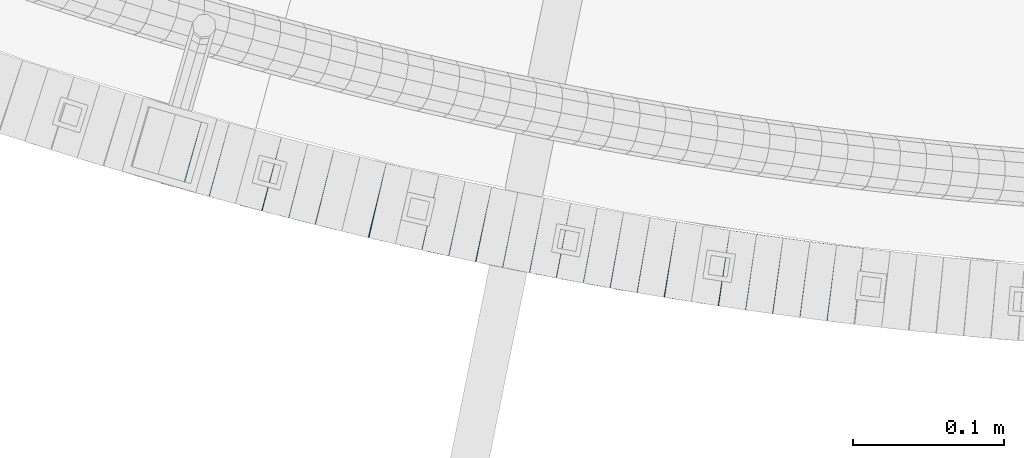
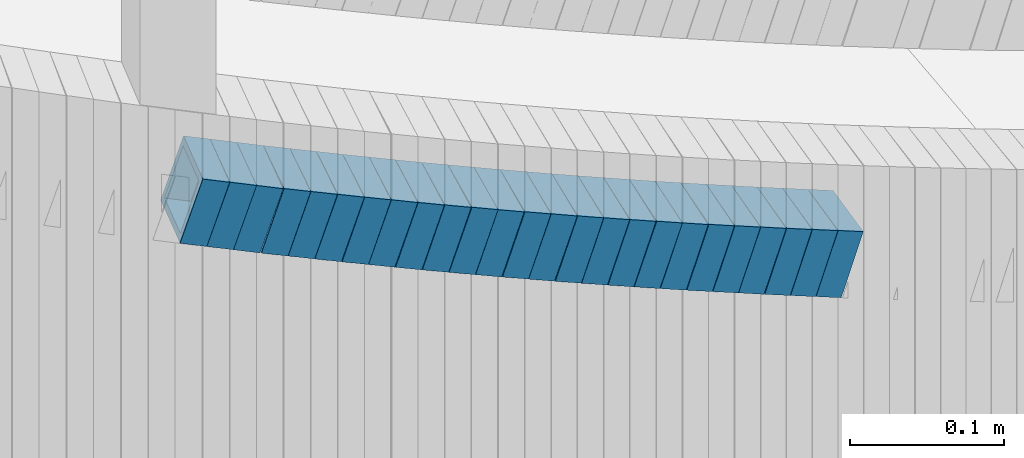
# One storey, part 671 of 975: 25 beams.
"""IFC2X3 building model written with IfcOpenShell, lengths in millimetres."""

from ifc_helpers import new_model, si_unit, frame, origin_with_axes, place, context, subcontext, project, spatial, faceted_brep, material, type_object, element, save


model = new_model("IFC2X3")

# Units and contexts
model_context = context("Model", 3, precision=1e-05, world=origin_with_axes())
body_context = subcontext(model_context, "Body", "Model", "MODEL_VIEW")
ifc_project = project(units=[si_unit("LENGTHUNIT", "METRE", prefix="MILLI"), si_unit("AREAUNIT", "SQUARE_METRE"), si_unit("VOLUMEUNIT", "CUBIC_METRE"), si_unit("MASSUNIT", "GRAM", prefix="KILO"), si_unit("TIMEUNIT", "SECOND"), si_unit("PLANEANGLEUNIT", "RADIAN"), si_unit("SOLIDANGLEUNIT", "STERADIAN"), si_unit("THERMODYNAMICTEMPERATUREUNIT", "DEGREE_CELSIUS"), si_unit("LUMINOUSINTENSITYUNIT", "LUMEN")], contexts=[model_context])

# Site, building, storey
site_placement = place(None, origin_with_axes())
site = spatial("IfcSite", under=ifc_project, at=site_placement, CompositionType="ELEMENT")
building_placement = place(site_placement, origin_with_axes())
building = spatial("IfcBuilding", under=site, at=building_placement, Name="Undefined", CompositionType="ELEMENT")
storey_placement = place(building_placement, origin_with_axes())
storey = spatial("IfcBuildingStorey", under=building, at=storey_placement, Name="Undefined", CompositionType="ELEMENT", Elevation=0.0)

# Beams
ifc_material = material()
beam_type = type_object("IfcBeamType", Name="HSS2X2X.188_TUBES", PredefinedType="NOTDEFINED")
for number, where, z_axis, x_axis, name in (
    (1, (33942.9680907817, 644.253471281401, 3543.29082249187), (0.267356577272934, 0.963597665308972, 2.4865676095942e-10), (0.918421532894371, -0.254822158970696, -0.302601313965203), "WALL"),
    (2, (33960.2608075269, 639.412258861512, 3537.63333455663), (0.262173284244731, 0.965020812743607, -9.81567609414923e-11), (0.918162800504618, -0.249443072865418, -0.307823366833929), "WALL"),
    (3, (33977.5608075269, 634.71225886151, 3531.83333455663), (0.262173284244731, 0.965020812743607, -9.81567609414923e-11), (0.918162800504618, -0.249443072865418, -0.307823366833929), "WALL"),
):
    element("IfcBeam", number, at=place(storey_placement, frame(where, z_axis=z_axis, x_axis=x_axis)), inside=storey, type_object=beam_type, material=ifc_material, Name=name, ObjectType="HSS2X2X.188_TUBES", context=body_context, shape_type="Brep", body=[
        faceted_brep([(0.0, 20.6374999999753, -20.6375000000298), (0.0, -20.6375000000153, -20.6375000000153), (18.8433011969464, -20.6374999999898, -20.6375000000226), (18.8433011969719, 20.6375000000007, -20.6374999999862), (0.0, -20.6374999999825, 20.6375000000335), (18.8433011969828, -20.6375000000044, 20.6375000000189), (0.0, 20.6375000000116, 20.6375000000189), (18.8433011970155, 20.6374999999862, 20.6375000000517), (0.0, 25.3999999999724, -25.4000000000342), (0.0, 25.400000000016, 25.4000000000196), (18.8433011970228, 25.3999999999833, 25.4000000000597), (18.8433011969719, 25.4000000000015, -25.3999999999869), (0.0, -25.399999999976, 25.4000000000378), (18.8433011969864, -25.4000000000051, 25.4000000000196), (0.0, -25.400000000016, -25.4000000000196), (18.8433011969391, -25.3999999999869, -25.4000000000269)], [[[0, 1, 2, 3]], [[1, 4, 5, 2]], [[4, 6, 7, 5]], [[6, 0, 3, 7]], [[8, 9, 10, 11]], [[9, 12, 13, 10]], [[12, 14, 15, 13]], [[14, 8, 11, 15]], [[13, 15, 11, 10], [5, 7, 3, 2]], [[14, 12, 9, 8], [6, 4, 1, 0]]]),
    ])
beam_1_placement = place(storey_placement, frame((33995.2713785459, 629.805617457047, 3525.98848877912), z_axis=(0.250382821654522, 0.968146911692807, 8.16853571450337e-11), x_axis=(0.922846449748657, -0.238667184934995, -0.302311767917665)))
element("IfcBeam", 4, at=beam_1_placement, inside=storey, type_object=beam_type, material=ifc_material, Name="WALL", ObjectType="HSS2X2X.188_TUBES", context=body_context, shape_type="Brep", body=[
    faceted_brep([(0.0, 20.6374999999753, -20.6375000000298), (0.0, -20.6375000000153, -20.6375000000153), (18.8480768248774, -20.6374999999716, -20.6375000000735), (18.8480768249356, 20.6375000000153, -20.6375000000226), (0.0, -20.6374999999825, 20.6375000000335), (18.8480768249283, -20.6374999999935, 20.6374999999716), (0.0, 20.6375000000116, 20.6375000000189), (18.8480768249865, 20.6374999999935, 20.6375000000262), (0.0, 25.3999999999724, -25.4000000000342), (0.0, 25.400000000016, 25.4000000000196), (18.848076825001, 25.3999999999887, 25.4000000000378), (18.8480768249392, 25.4000000000142, -25.4000000000233), (0.0, -25.399999999976, 25.4000000000378), (18.8480768249283, -25.399999999996, 25.3999999999833), (0.0, -25.400000000016, -25.4000000000196), (18.8480768248664, -25.3999999999687, -25.4000000000779)], [[[0, 1, 2, 3]], [[1, 4, 5, 2]], [[4, 6, 7, 5]], [[6, 0, 3, 7]], [[8, 9, 10, 11]], [[9, 12, 13, 10]], [[12, 14, 15, 13]], [[14, 8, 11, 15]], [[13, 15, 11, 10], [5, 7, 3, 2]], [[14, 12, 9, 8], [6, 4, 1, 0]]]),
])
beam_2_placement = place(storey_placement, frame((34012.7165786276, 625.262051182556, 3520.30361280791), z_axis=(0.246487962209947, 0.969145853050813, 2.48490778176347e-10), x_axis=(0.923221587142403, -0.234807802036218, -0.304182835046923)))
element("IfcBeam", 5, at=beam_2_placement, inside=storey, type_object=beam_type, material=ifc_material, Name="WALL", ObjectType="HSS2X2X.188_TUBES", context=body_context, shape_type="Brep", body=[
    faceted_brep([(0.0, 20.6374999999753, -20.6375000000298), (0.0, -20.6375000000153, -20.6375000000153), (18.7416648140024, -20.6375000000153, -20.6374999999825), (18.7416648139188, 20.6375000000189, -20.6375000000298), (0.0, -20.6374999999825, 20.6375000000335), (18.7416648140097, -20.6375000000189, 20.6375000000226), (0.0, 20.6375000000116, 20.6375000000189), (18.741664813926, 20.6375000000153, 20.6374999999753), (0.0, 25.3999999999724, -25.4000000000342), (0.0, 25.400000000016, 25.4000000000196), (18.7416648139224, 25.4000000000196, 25.3999999999687), (18.7416648139042, 25.4000000000233, -25.4000000000378), (0.0, -25.399999999976, 25.4000000000378), (18.7416648140133, -25.4000000000215, 25.4000000000269), (0.0, -25.400000000016, -25.4000000000196), (18.7416648140133, -25.4000000000196, -25.399999999976)], [[[0, 1, 2, 3]], [[1, 4, 5, 2]], [[4, 6, 7, 5]], [[6, 0, 3, 7]], [[8, 9, 10, 11]], [[9, 12, 13, 10]], [[12, 14, 15, 13]], [[14, 8, 11, 15]], [[13, 15, 11, 10], [5, 7, 3, 2]], [[14, 12, 9, 8], [6, 4, 1, 0]]]),
])
beam_3_placement = place(storey_placement, frame((34030.0797760681, 620.791852995655, 3514.63379787298), z_axis=(0.239909191617451, 0.970795333619533, 9.06384229892865e-11), x_axis=(0.923639222967941, -0.228255669992075, -0.307879740989314)))
element("IfcBeam", 6, at=beam_3_placement, inside=storey, type_object=beam_type, material=ifc_material, Name="WALL", ObjectType="HSS2X2X.188_TUBES", context=body_context, shape_type="Brep", body=[
    faceted_brep([(0.0, 20.6374999999753, -20.6375000000298), (0.0, -20.6375000000153, -20.6375000000153), (18.8433011969464, -20.6374999999898, -20.6375000000226), (18.8433011969719, 20.6375000000007, -20.6374999999862), (0.0, -20.6374999999825, 20.6375000000335), (18.8433011969828, -20.6375000000044, 20.6375000000189), (0.0, 20.6375000000116, 20.6375000000189), (18.8433011970155, 20.6374999999862, 20.6375000000517), (0.0, 25.3999999999724, -25.4000000000342), (0.0, 25.400000000016, 25.4000000000196), (18.8433011970228, 25.3999999999833, 25.4000000000597), (18.8433011969719, 25.4000000000015, -25.3999999999869), (0.0, -25.399999999976, 25.4000000000378), (18.8433011969864, -25.4000000000051, 25.4000000000196), (0.0, -25.400000000016, -25.4000000000196), (18.8433011969391, -25.3999999999869, -25.4000000000269)], [[[0, 1, 2, 3]], [[1, 4, 5, 2]], [[4, 6, 7, 5]], [[6, 0, 3, 7]], [[8, 9, 10, 11]], [[9, 12, 13, 10]], [[12, 14, 15, 13]], [[14, 8, 11, 15]], [[13, 15, 11, 10], [5, 7, 3, 2]], [[14, 12, 9, 8], [6, 4, 1, 0]]]),
])
for number, where, z_axis, x_axis, name in (
    (7, (34047.7134620733, 616.391430923569, 3508.79749634809), (0.234640533210091, 0.972082208547654, -9.88338797469624e-11), (0.926252882322659, -0.223578282077887, -0.303427668105709), "WALL"),
    (8, (34065.1099416318, 612.148817747955, 3503.13981683548), (0.229351114565448, 0.973343755436684, 1.69726263266057e-10), (0.925833205726166, -0.218156099935475, -0.308611067908709), "WALL"),
):
    element("IfcBeam", number, at=place(storey_placement, frame(where, z_axis=z_axis, x_axis=x_axis)), inside=storey, type_object=beam_type, material=ifc_material, Name=name, ObjectType="HSS2X2X.188_TUBES", context=body_context, shape_type="Brep", body=[
        faceted_brep([(0.0, 20.6374999999753, -20.6375000000298), (0.0, -20.6375000000153, -20.6375000000153), (18.7853666454903, -20.6375000000535, -20.6375000000326), (18.785366645363, 20.6374999999862, -20.6375000000044), (0.0, -20.6374999999825, 20.6375000000335), (18.785366645352, -20.6375000000007, 20.6374999999989), (0.0, 20.6375000000116, 20.6375000000189), (18.7853666453102, 20.6375000000025, 20.6374999999753), (0.0, 25.3999999999724, -25.4000000000342), (0.0, 25.400000000016, 25.4000000000196), (18.7853666452065, 25.4000000000451, 25.4000000000351), (18.7853666453739, 25.3999999999833, -25.400000000006), (0.0, -25.399999999976, 25.4000000000378), (18.7853666497213, -25.399999993424, 25.3999999995158), (0.0, -25.400000000016, -25.4000000000196), (18.7853666455194, -25.4000000000633, -25.4000000000406)], [[[0, 1, 2, 3]], [[1, 4, 5, 2]], [[4, 6, 7, 5]], [[6, 0, 3, 7]], [[8, 9, 10, 11]], [[9, 12, 13, 10]], [[12, 14, 15, 13]], [[14, 8, 11, 15]], [[13, 15, 11, 10], [5, 7, 3, 2]], [[14, 12, 9, 8], [6, 4, 1, 0]]]),
    ])
beam_4_placement = place(storey_placement, frame((34082.7459201724, 607.950333243549, 3497.30322650391), z_axis=(0.22404129864445, 0.974579651183888, 1.23778590932488e-10), x_axis=(0.928412719816283, -0.213428210957767, -0.304135200939811)))
element("IfcBeam", 9, at=beam_4_placement, inside=storey, type_object=beam_type, material=ifc_material, Name="WALL", ObjectType="HSS2X2X.188_TUBES", context=body_context, shape_type="Brep", body=[
    faceted_brep([(0.0, 20.6374999999753, -20.6375000000298), (0.0, -20.6375000000153, -20.6375000000153), (18.7416648140024, -20.6375000000153, -20.6374999999825), (18.7416648139188, 20.6375000000189, -20.6375000000298), (0.0, -20.6374999999825, 20.6375000000335), (18.7416648140097, -20.6375000000189, 20.6375000000226), (0.0, 20.6375000000116, 20.6375000000189), (18.741664813926, 20.6375000000153, 20.6374999999753), (0.0, 25.3999999999724, -25.4000000000342), (0.0, 25.400000000016, 25.4000000000196), (18.7416648139224, 25.4000000000196, 25.3999999999687), (18.7416648139042, 25.4000000000233, -25.4000000000378), (0.0, -25.399999999976, 25.4000000000378), (18.7416648140133, -25.4000000000215, 25.4000000000269), (0.0, -25.400000000016, -25.4000000000196), (18.7416648140133, -25.4000000000196, -25.399999999976)], [[[0, 1, 2, 3]], [[1, 4, 5, 2]], [[4, 6, 7, 5]], [[6, 0, 3, 7]], [[8, 9, 10, 11]], [[9, 12, 13, 10]], [[12, 14, 15, 13]], [[14, 8, 11, 15]], [[13, 15, 11, 10], [5, 7, 3, 2]], [[14, 12, 9, 8], [6, 4, 1, 0]]]),
])
beam_5_placement = place(storey_placement, frame((34100.3289479344, 603.856051884226, 3491.59382167691), z_axis=(0.217520973282852, 0.976055647072482, -8.27567419037223e-11), x_axis=(0.930180198984983, -0.20729730199665, -0.302972978995104)))
element("IfcBeam", 10, at=beam_5_placement, inside=storey, type_object=beam_type, material=ifc_material, Name="WALL", ObjectType="HSS2X2X.188_TUBES", context=body_context, shape_type="Brep", body=[
    faceted_brep([(0.0, 20.6374999999753, -20.6375000000298), (0.0, -20.6375000000153, -20.6375000000153), (18.8066477608099, -20.6374999999862, -20.6375000000116), (18.8066477608172, 20.6375000000062, -20.6374999999971), (0.0, -20.6374999999825, 20.6375000000335), (18.8066477608463, -20.6375000000062, 20.6375000000407), (0.0, 20.6375000000116, 20.6375000000189), (18.8066477608536, 20.6374999999844, 20.637500000048), (0.0, 25.3999999999724, -25.4000000000342), (0.0, 25.400000000016, 25.4000000000196), (18.8066477608591, 25.3999999999814, 25.400000000056), (18.8066477608154, 25.4000000000051, -25.4000000000015), (0.0, -25.399999999976, 25.4000000000378), (18.8066477608518, -25.4000000000087, 25.4000000000451), (0.0, -25.400000000016, -25.4000000000196), (18.8066477608081, -25.3999999999851, -25.4000000000196)], [[[0, 1, 2, 3]], [[1, 4, 5, 2]], [[4, 6, 7, 5]], [[6, 0, 3, 7]], [[8, 9, 10, 11]], [[9, 12, 13, 10]], [[12, 14, 15, 13]], [[14, 8, 11, 15]], [[13, 15, 11, 10], [5, 7, 3, 2]], [[14, 12, 9, 8], [6, 4, 1, 0]]]),
])
beam_6_placement = place(storey_placement, frame((34117.9459285247, 599.843929836228, 3485.93848619024), z_axis=(0.206855682001187, 0.978371466685238, -2.1488631318789e-11), x_axis=(0.930666760188665, -0.196769544039887, -0.308449555062525)))
element("IfcBeam", 11, at=beam_6_placement, inside=storey, type_object=beam_type, material=ifc_material, Name="WALL", ObjectType="HSS2X2X.188_TUBES", context=body_context, shape_type="Brep", body=[
    faceted_brep([(0.0, 20.6374999999753, -20.6375000000298), (0.0, -20.6375000000153, -20.6375000000153), (18.8047866246379, -20.6374999999916, -20.6375000000298), (18.8047866247143, 20.6374999999844, -20.6374999999643), (0.0, -20.6374999999825, 20.6375000000335), (18.8047866247107, -20.6375000000189, 20.6375000000407), (0.0, 20.6375000000116, 20.6375000000189), (18.8047866247907, 20.6374999999589, 20.6375000001026), (0.0, 25.3999999999724, -25.4000000000342), (0.0, 25.400000000016, 25.4000000000196), (18.8047866248016, 25.3999999999542, 25.4000000001142), (18.8047866247143, 25.3999999999851, -25.3999999999651), (0.0, -25.399999999976, 25.4000000000378), (18.8047866247107, -25.4000000000196, 25.4000000000415), (0.0, -25.400000000016, -25.4000000000196), (18.8047866246197, -25.3999999999887, -25.4000000000378)], [[[0, 1, 2, 3]], [[1, 4, 5, 2]], [[4, 6, 7, 5]], [[6, 0, 3, 7]], [[8, 9, 10, 11]], [[9, 12, 13, 10]], [[12, 14, 15, 13]], [[14, 8, 11, 15]], [[13, 15, 11, 10], [5, 7, 3, 2]], [[14, 12, 9, 8], [6, 4, 1, 0]]]),
])
beam_7_placement = place(storey_placement, frame((34135.5658062645, 596.118584256949, 3480.09909806896), z_axis=(0.206855682001187, 0.978371466685238, -2.1488631318789e-11), x_axis=(0.932183934090213, -0.197090318019077, -0.303625624029385)))
element("IfcBeam", 12, at=beam_7_placement, inside=storey, type_object=beam_type, material=ifc_material, Name="WALL", ObjectType="HSS2X2X.188_TUBES", context=body_context, shape_type="Brep", body=[
    faceted_brep([(0.0, 20.6374999999753, -20.6375000000298), (0.0, -20.6375000000153, -20.6375000000153), (18.767258723612, -20.6375000000025, -20.6374999999862), (18.7672587236229, 20.6374999999953, -20.637499999968), (0.0, -20.6374999999825, 20.6375000000335), (18.767258723612, -20.6375000000135, 20.6375000000153), (0.0, 20.6375000000116, 20.6375000000189), (18.7672587236266, 20.6374999999844, 20.6375000000371), (0.0, 25.3999999999724, -25.4000000000342), (0.0, 25.400000000016, 25.4000000000196), (18.7672587236302, 25.3999999999814, 25.4000000000342), (18.7672587236229, 25.399999999996, -25.3999999999687), (0.0, -25.399999999976, 25.4000000000378), (18.7672587236157, -25.4000000000142, 25.400000000016), (0.0, -25.400000000016, -25.4000000000196), (18.767258723612, -25.4000000000015, -25.3999999999905)], [[[0, 1, 2, 3]], [[1, 4, 5, 2]], [[4, 6, 7, 5]], [[6, 0, 3, 7]], [[8, 9, 10, 11]], [[9, 12, 13, 10]], [[12, 14, 15, 13]], [[14, 8, 11, 15]], [[13, 15, 11, 10], [5, 7, 3, 2]], [[14, 12, 9, 8], [6, 4, 1, 0]]]),
])
beam_8_placement = place(storey_placement, frame((34153.3060560939, 592.282745398886, 3474.40413998626), z_axis=(0.196116135486765, 0.980580675621204, -1.76175490196329e-10), x_axis=(0.934094203440654, -0.186818841088129, -0.304247826143523)))
element("IfcBeam", 13, at=beam_8_placement, inside=storey, type_object=beam_type, material=ifc_material, Name="WALL", ObjectType="HSS2X2X.188_TUBES", context=body_context, shape_type="Brep", body=[
    faceted_brep([(0.0, 20.6374999999753, -20.6375000000298), (0.0, -20.6375000000153, -20.6375000000153), (18.7347271129966, -20.6375000000116, -20.6375000000262), (18.7347271130257, 20.6374999999989, -20.6374999999935), (0.0, -20.6374999999825, 20.6375000000335), (18.7347271129947, -20.6375000000116, 20.6374999999607), (0.0, 20.6375000000116, 20.6375000000189), (18.7347271130147, 20.6375000000007, 20.6374999999898), (0.0, 25.3999999999724, -25.4000000000342), (0.0, 25.400000000016, 25.4000000000196), (18.7347271130166, 25.4000000000015, 25.3999999999905), (18.7347271130257, 25.3999999999996, -25.3999999999869), (0.0, -25.399999999976, 25.4000000000378), (18.7347271129875, -25.4000000000106, 25.3999999999505), (0.0, -25.400000000016, -25.4000000000196), (18.7347271130002, -25.4000000000124, -25.4000000000233)], [[[0, 1, 2, 3]], [[1, 4, 5, 2]], [[4, 6, 7, 5]], [[6, 0, 3, 7]], [[8, 9, 10, 11]], [[9, 12, 13, 10]], [[12, 14, 15, 13]], [[14, 8, 11, 15]], [[13, 15, 11, 10], [5, 7, 3, 2]], [[14, 12, 9, 8], [6, 4, 1, 0]]]),
])
beam_9_placement = place(storey_placement, frame((34170.8068732929, 588.73889334774, 3468.74618576698), z_axis=(0.1907195173043, 0.981644571990909, -9.77493073150981e-11), x_axis=(0.933482702257015, -0.181362354049934, -0.309382839085184)))
element("IfcBeam", 14, at=beam_9_placement, inside=storey, type_object=beam_type, material=ifc_material, Name="WALL", ObjectType="HSS2X2X.188_TUBES", context=body_context, shape_type="Brep", body=[
    faceted_brep([(0.0, 20.6374999999753, -20.6375000000298), (0.0, -20.6375000000153, -20.6375000000153), (18.7547327359644, -20.6374999999844, -20.6375000000553), (18.7547327359898, 20.6375000000171, -20.6375000000335), (0.0, -20.6374999999825, 20.6375000000335), (18.7547327360044, -20.6374999999953, 20.6374999999898), (0.0, 20.6375000000116, 20.6375000000189), (18.7547327360262, 20.6375000000062, 20.6375000000116), (0.0, 25.3999999999724, -25.4000000000342), (0.0, 25.400000000016, 25.4000000000196), (18.7547327360371, 25.4000000000033, 25.4000000000124), (18.7547327359898, 25.4000000000178, -25.4000000000342), (0.0, -25.399999999976, 25.4000000000378), (18.7547327360044, -25.399999999996, 25.3999999999869), (0.0, -25.400000000016, -25.4000000000196), (18.7547327359498, -25.3999999999814, -25.4000000000597)], [[[0, 1, 2, 3]], [[1, 4, 5, 2]], [[4, 6, 7, 5]], [[6, 0, 3, 7]], [[8, 9, 10, 11]], [[9, 12, 13, 10]], [[12, 14, 15, 13]], [[14, 8, 11, 15]], [[13, 15, 11, 10], [5, 7, 3, 2]], [[14, 12, 9, 8], [6, 4, 1, 0]]]),
])
beam_10_placement = place(storey_placement, frame((34188.6119255804, 585.228796626352, 3462.89662764212), z_axis=(0.18428853487203, 0.982872186967726, 3.81432982976549e-11), x_axis=(0.936567776700519, -0.175606457943848, -0.303320245903009)))
element("IfcBeam", 15, at=beam_10_placement, inside=storey, type_object=beam_type, material=ifc_material, Name="WALL", ObjectType="HSS2X2X.188_TUBES", context=body_context, shape_type="Brep", body=[
    faceted_brep([(0.0, 20.6374999999753, -20.6375000000298), (0.0, -20.6375000000153, -20.6375000000153), (18.7853666454903, -20.6375000000535, -20.6375000000326), (18.785366645363, 20.6374999999862, -20.6375000000044), (0.0, -20.6374999999825, 20.6375000000335), (18.785366645352, -20.6375000000007, 20.6374999999989), (0.0, 20.6375000000116, 20.6375000000189), (18.7853666453102, 20.6375000000025, 20.6374999999753), (0.0, 25.3999999999724, -25.4000000000342), (0.0, 25.400000000016, 25.4000000000196), (18.7853666452065, 25.4000000000451, 25.4000000000351), (18.7853666453739, 25.3999999999833, -25.400000000006), (0.0, -25.399999999976, 25.4000000000378), (18.7853666497213, -25.399999993424, 25.3999999995158), (0.0, -25.400000000016, -25.4000000000196), (18.7853666455194, -25.4000000000633, -25.4000000000406)], [[[0, 1, 2, 3]], [[1, 4, 5, 2]], [[4, 6, 7, 5]], [[6, 0, 3, 7]], [[8, 9, 10, 11]], [[9, 12, 13, 10]], [[12, 14, 15, 13]], [[14, 8, 11, 15]], [[13, 15, 11, 10], [5, 7, 3, 2]], [[14, 12, 9, 8], [6, 4, 1, 0]]]),
])
beam_11_placement = place(storey_placement, frame((34206.2727041076, 581.882265226311, 3457.21124902149), z_axis=(0.179874658326109, 0.983689538061713, -9.92245077213738e-11), x_axis=(0.936780365329598, -0.171296981060271, -0.305122748107352)))
element("IfcBeam", 16, at=beam_11_placement, inside=storey, type_object=beam_type, material=ifc_material, Name="WALL", ObjectType="HSS2X2X.188_TUBES", context=body_context, shape_type="Brep", body=[
    faceted_brep([(0.0, 20.6374999999753, -20.6375000000298), (0.0, -20.6375000000153, -20.6375000000153), (18.677794302308, -20.6374999999989, -20.6374999999862), (18.6777943022862, 20.6375000000098, -20.6375000000153), (0.0, -20.6374999999825, 20.6375000000335), (18.6777943022862, -20.6375000000044, 20.6374999999862), (0.0, 20.6375000000116, 20.6375000000189), (18.6777943022644, 20.6375000000044, 20.6374999999571), (0.0, 25.3999999999724, -25.4000000000342), (0.0, 25.400000000016, 25.4000000000196), (18.6777943022607, 25.4000000000033, 25.3999999999505), (18.6777943022898, 25.4000000000124, -25.400000000016), (0.0, -25.399999999976, 25.4000000000378), (18.6777943022862, -25.4000000000069, 25.3999999999905), (0.0, -25.400000000016, -25.4000000000196), (18.6777943023117, -25.3999999999978, -25.3999999999796)], [[[0, 1, 2, 3]], [[1, 4, 5, 2]], [[4, 6, 7, 5]], [[6, 0, 3, 7]], [[8, 9, 10, 11]], [[9, 12, 13, 10]], [[12, 14, 15, 13]], [[14, 8, 11, 15]], [[13, 15, 11, 10], [5, 7, 3, 2]], [[14, 12, 9, 8], [6, 4, 1, 0]]]),
])
for number, where, z_axis, x_axis, name in (
    (17, (34223.9578672936, 578.597867310617, 3451.50108876772), (0.173466107820015, 0.984839839485474, 8.33979356684722e-11), (0.938269758220202, -0.165263423038788, -0.303871456071325), "WALL"),
    (18, (34241.6858829932, 575.388825618842, 3445.84487770984), (0.16258047371373, 0.98669528709071, -2.24193172471132e-10), (0.938336430405657, -0.154612253066841, -0.309224505133674), "WALL"),
):
    element("IfcBeam", number, at=place(storey_placement, frame(where, z_axis=z_axis, x_axis=x_axis)), inside=storey, type_object=beam_type, material=ifc_material, Name=name, ObjectType="HSS2X2X.188_TUBES", context=body_context, shape_type="Brep", body=[
        faceted_brep([(0.0, 20.6374999999753, -20.6375000000298), (0.0, -20.6375000000153, -20.6375000000153), (18.7555325170906, -20.6374999999916, -20.6374999999971), (18.7555325171452, 20.637499999988, -20.6374999999571), (0.0, -20.6374999999825, 20.6375000000335), (18.7555325170615, -20.6374999999844, 20.6374999999716), (0.0, 20.6375000000116, 20.6375000000189), (18.7555325171015, 20.6374999999953, 20.637500000008), (0.0, 25.3999999999724, -25.4000000000342), (0.0, 25.400000000016, 25.4000000000196), (18.7555325171015, 25.399999999996, 25.4000000000051), (18.7555325171488, 25.3999999999851, -25.3999999999505), (0.0, -25.399999999976, 25.4000000000378), (18.755532517047, -25.3999999999814, 25.3999999999578), (0.0, -25.400000000016, -25.4000000000196), (18.7555325170979, -25.3999999999924, -25.3999999999978)], [[[0, 1, 2, 3]], [[1, 4, 5, 2]], [[4, 6, 7, 5]], [[6, 0, 3, 7]], [[8, 9, 10, 11]], [[9, 12, 13, 10]], [[12, 14, 15, 13]], [[14, 8, 11, 15]], [[13, 15, 11, 10], [5, 7, 3, 2]], [[14, 12, 9, 8], [6, 4, 1, 0]]]),
    ])
beam_12_placement = place(storey_placement, frame((34259.4667206778, 572.45197182975, 3439.99299280673), z_axis=(0.161686018621847, 0.986842252531891, 1.45924786920659e-10), x_axis=(0.940492028096781, -0.154091914015857, -0.302870314031161)))
element("IfcBeam", 19, at=beam_12_placement, inside=storey, type_object=beam_type, material=ifc_material, Name="WALL", ObjectType="HSS2X2X.188_TUBES", context=body_context, shape_type="Brep", body=[
    faceted_brep([(0.0, 20.6374999999753, -20.6375000000298), (0.0, -20.6375000000153, -20.6375000000153), (18.8225928075335, -20.6374999999935, -20.6375000000298), (18.8225928075699, 20.6374999999898, -20.6374999999825), (0.0, -20.6374999999825, 20.6375000000335), (18.8225928075772, -20.637500000008, 20.6375000000226), (0.0, 20.6375000000116, 20.6375000000189), (18.8225928076135, 20.6374999999753, 20.6375000000698), (0.0, 25.3999999999724, -25.4000000000342), (0.0, 25.400000000016, 25.4000000000196), (18.8225928076281, 25.3999999999705, 25.4000000000815), (18.8225928075663, 25.3999999999905, -25.3999999999796), (0.0, -25.399999999976, 25.4000000000378), (18.8225928075808, -25.4000000000087, 25.4000000000233), (0.0, -25.400000000016, -25.4000000000196), (18.8225928075226, -25.3999999999905, -25.4000000000378)], [[[0, 1, 2, 3]], [[1, 4, 5, 2]], [[4, 6, 7, 5]], [[6, 0, 3, 7]], [[8, 9, 10, 11]], [[9, 12, 13, 10]], [[12, 14, 15, 13]], [[14, 8, 11, 15]], [[13, 15, 11, 10], [5, 7, 3, 2]], [[14, 12, 9, 8], [6, 4, 1, 0]]]),
])
beam_13_placement = place(storey_placement, frame((34277.3593367676, 569.441890252747, 3434.30925996803), z_axis=(0.151635150261835, 0.988436533726405, -9.61290425038897e-11), x_axis=(0.941378395041404, -0.144416004006351, -0.304878230013408)))
element("IfcBeam", 20, at=beam_13_placement, inside=storey, type_object=beam_type, material=ifc_material, Name="WALL", ObjectType="HSS2X2X.188_TUBES", context=body_context, shape_type="Brep", body=[
    faceted_brep([(0.0, 20.6374999999753, -20.6375000000298), (0.0, -20.6375000000153, -20.6375000000153), (18.6959888745805, -20.6374999999771, -20.6375000000407), (18.6959888746751, 20.637499999988, -20.6374999999716), (0.0, -20.6374999999825, 20.6375000000335), (18.6959888746969, -20.6375000000135, 20.6375000000371), (0.0, 20.6375000000116, 20.6375000000189), (18.6959888747988, 20.6374999999498, 20.6375000001062), (0.0, 25.3999999999724, -25.4000000000342), (0.0, 25.400000000016, 25.4000000000196), (18.695988874817, 25.3999999999414, 25.4000000001215), (18.6959888746678, 25.3999999999887, -25.399999999976), (0.0, -25.399999999976, 25.4000000000378), (18.6959888747042, -25.4000000000124, 25.4000000000378), (0.0, -25.400000000016, -25.4000000000196), (18.695988874555, -25.3999999999687, -25.4000000000597)], [[[0, 1, 2, 3]], [[1, 4, 5, 2]], [[4, 6, 7, 5]], [[6, 0, 3, 7]], [[8, 9, 10, 11]], [[9, 12, 13, 10]], [[12, 14, 15, 13]], [[14, 8, 11, 15]], [[13, 15, 11, 10], [5, 7, 3, 2]], [[14, 12, 9, 8], [6, 4, 1, 0]]]),
])
beam_14_placement = place(storey_placement, frame((34295.14475091, 566.664253826269, 3428.59871465884), z_axis=(0.14533306454886, 0.989382787574575, 1.22513483802322e-10), x_axis=(0.942690360622597, -0.138474289944563, -0.30357825187847)))
element("IfcBeam", 21, at=beam_14_placement, inside=storey, type_object=beam_type, material=ifc_material, Name="WALL", ObjectType="HSS2X2X.188_TUBES", context=body_context, shape_type="Brep", body=[
    faceted_brep([(0.0, 20.6374999999753, -20.6375000000298), (0.0, -20.6375000000153, -20.6375000000153), (18.7771137292038, -20.637500000008, -20.6374999999862), (18.777113729182, 20.6375000000062, -20.6375000000189), (0.0, -20.6374999999825, 20.6375000000335), (18.7771137291729, -20.6374999999916, 20.6374999999753), (0.0, 20.6375000000116, 20.6375000000189), (18.7771137291529, 20.6375000000207, 20.6374999999389), (0.0, 25.3999999999724, -25.4000000000342), (0.0, 25.400000000016, 25.4000000000196), (18.7771137291475, 25.4000000000251, 25.3999999999287), (18.7771137291857, 25.4000000000051, -25.4000000000196), (0.0, -25.399999999976, 25.4000000000378), (18.7771137291711, -25.3999999999905, 25.3999999999724), (0.0, -25.400000000016, -25.4000000000196), (18.7771137292129, -25.4000000000124, -25.3999999999724)], [[[0, 1, 2, 3]], [[1, 4, 5, 2]], [[4, 6, 7, 5]], [[6, 0, 3, 7]], [[8, 9, 10, 11]], [[9, 12, 13, 10]], [[12, 14, 15, 13]], [[14, 8, 11, 15]], [[13, 15, 11, 10], [5, 7, 3, 2]], [[14, 12, 9, 8], [6, 4, 1, 0]]]),
])
beam_15_placement = place(storey_placement, frame((34312.8509061586, 564.019889719854, 3422.93992485104), z_axis=(0.139854805609575, 0.990172022099144, -1.91341769095743e-10), x_axis=(0.94183584538687, -0.13302766205464, -0.308624175126766)))
element("IfcBeam", 22, at=beam_15_placement, inside=storey, type_object=beam_type, material=ifc_material, Name="WALL", ObjectType="HSS2X2X.188_TUBES", context=body_context, shape_type="Brep", body=[
    faceted_brep([(0.0, 20.6374999999753, -20.6375000000298), (0.0, -20.6375000000153, -20.6375000000153), (18.7853666454903, -20.6375000000535, -20.6375000000326), (18.785366645363, 20.6374999999862, -20.6375000000044), (0.0, -20.6374999999825, 20.6375000000335), (18.785366645352, -20.6375000000007, 20.6374999999989), (0.0, 20.6375000000116, 20.6375000000189), (18.7853666453102, 20.6375000000025, 20.6374999999753), (0.0, 25.3999999999724, -25.4000000000342), (0.0, 25.400000000016, 25.4000000000196), (18.7853666452065, 25.4000000000451, 25.4000000000351), (18.7853666453739, 25.3999999999833, -25.400000000006), (0.0, -25.399999999976, 25.4000000000378), (18.7853666497213, -25.399999993424, 25.3999999995158), (0.0, -25.400000000016, -25.4000000000196), (18.7853666455194, -25.4000000000633, -25.4000000000406)], [[[0, 1, 2, 3]], [[1, 4, 5, 2]], [[4, 6, 7, 5]], [[6, 0, 3, 7]], [[8, 9, 10, 11]], [[9, 12, 13, 10]], [[12, 14, 15, 13]], [[14, 8, 11, 15]], [[13, 15, 11, 10], [5, 7, 3, 2]], [[14, 12, 9, 8], [6, 4, 1, 0]]]),
])
beam_16_placement = place(storey_placement, frame((34330.8005668508, 561.441790402111, 3417.10220925443), z_axis=(0.134363672724503, 0.990932088213911, 9.62886588240509e-11), x_axis=(0.944030209667672, -0.128004095954939, -0.304009727892989)))
element("IfcBeam", 23, at=beam_16_placement, inside=storey, type_object=beam_type, material=ifc_material, Name="WALL", ObjectType="HSS2X2X.188_TUBES", context=body_context, shape_type="Brep", body=[
    faceted_brep([(0.0, 20.6374999999753, -20.6375000000298), (0.0, -20.6375000000153, -20.6375000000153), (18.7547327359644, -20.6374999999844, -20.6375000000553), (18.7547327359898, 20.6375000000171, -20.6375000000335), (0.0, -20.6374999999825, 20.6375000000335), (18.7547327360044, -20.6374999999953, 20.6374999999898), (0.0, 20.6375000000116, 20.6375000000189), (18.7547327360262, 20.6375000000062, 20.6375000000116), (0.0, 25.3999999999724, -25.4000000000342), (0.0, 25.400000000016, 25.4000000000196), (18.7547327360371, 25.4000000000033, 25.4000000000124), (18.7547327359898, 25.4000000000178, -25.4000000000342), (0.0, -25.399999999976, 25.4000000000378), (18.7547327360044, -25.399999999996, 25.3999999999869), (0.0, -25.400000000016, -25.4000000000196), (18.7547327359498, -25.3999999999814, -25.4000000000597)], [[[0, 1, 2, 3]], [[1, 4, 5, 2]], [[4, 6, 7, 5]], [[6, 0, 3, 7]], [[8, 9, 10, 11]], [[9, 12, 13, 10]], [[12, 14, 15, 13]], [[14, 8, 11, 15]], [[13, 15, 11, 10], [5, 7, 3, 2]], [[14, 12, 9, 8], [6, 4, 1, 0]]]),
])
beam_17_placement = place(storey_placement, frame((34348.6295903801, 558.981399235889, 3411.40385876698), z_axis=(0.128860134810268, 0.991662778194624, 6.80943230690901e-11), x_axis=(0.944661915133951, -0.122752678017409, -0.304213159043146)))
element("IfcBeam", 24, at=beam_17_placement, inside=storey, type_object=beam_type, material=ifc_material, Name="WALL", ObjectType="HSS2X2X.188_TUBES", context=body_context, shape_type="Brep", body=[
    faceted_brep([(0.0, 20.6374999999753, -20.6375000000298), (0.0, -20.6375000000153, -20.6375000000153), (18.7416648140024, -20.6375000000153, -20.6374999999825), (18.7416648139188, 20.6375000000189, -20.6375000000298), (0.0, -20.6374999999825, 20.6375000000335), (18.7416648140097, -20.6375000000189, 20.6375000000226), (0.0, 20.6375000000116, 20.6375000000189), (18.741664813926, 20.6375000000153, 20.6374999999753), (0.0, 25.3999999999724, -25.4000000000342), (0.0, 25.400000000016, 25.4000000000196), (18.7416648139224, 25.4000000000196, 25.3999999999687), (18.7416648139042, 25.4000000000233, -25.4000000000378), (0.0, -25.399999999976, 25.4000000000378), (18.7416648140133, -25.4000000000215, 25.4000000000269), (0.0, -25.400000000016, -25.4000000000196), (18.7416648140133, -25.4000000000196, -25.399999999976)], [[[0, 1, 2, 3]], [[1, 4, 5, 2]], [[4, 6, 7, 5]], [[6, 0, 3, 7]], [[8, 9, 10, 11]], [[9, 12, 13, 10]], [[12, 14, 15, 13]], [[14, 8, 11, 15]], [[13, 15, 11, 10], [5, 7, 3, 2]], [[14, 12, 9, 8], [6, 4, 1, 0]]]),
])
beam_18_placement = place(storey_placement, frame((34366.3375064683, 556.636728229832, 3405.74502291381), z_axis=(0.123344664337565, 0.992363891815625, 2.06371623789892e-10), x_axis=(0.943721538367317, -0.117298722045655, -0.309242086120373)))
element("IfcBeam", 25, at=beam_18_placement, inside=storey, type_object=beam_type, material=ifc_material, Name="WALL", ObjectType="HSS2X2X.188_TUBES", context=body_context, shape_type="Brep", body=[
    faceted_brep([(0.0, 20.6374999999753, -20.6375000000298), (0.0, -20.6375000000153, -20.6375000000153), (18.7555325170906, -20.6374999999916, -20.6374999999971), (18.7555325171452, 20.637499999988, -20.6374999999571), (0.0, -20.6374999999825, 20.6375000000335), (18.7555325170615, -20.6374999999844, 20.6374999999716), (0.0, 20.6375000000116, 20.6375000000189), (18.7555325171015, 20.6374999999953, 20.637500000008), (0.0, 25.3999999999724, -25.4000000000342), (0.0, 25.400000000016, 25.4000000000196), (18.7555325171015, 25.399999999996, 25.4000000000051), (18.7555325171488, 25.3999999999851, -25.3999999999505), (0.0, -25.399999999976, 25.4000000000378), (18.755532517047, -25.3999999999814, 25.3999999999578), (0.0, -25.400000000016, -25.4000000000196), (18.7555325170979, -25.3999999999924, -25.3999999999978)], [[[0, 1, 2, 3]], [[1, 4, 5, 2]], [[4, 6, 7, 5]], [[6, 0, 3, 7]], [[8, 9, 10, 11]], [[9, 12, 13, 10]], [[12, 14, 15, 13]], [[14, 8, 11, 15]], [[13, 15, 11, 10], [5, 7, 3, 2]], [[14, 12, 9, 8], [6, 4, 1, 0]]]),
])

save(model, "model.ifc")
